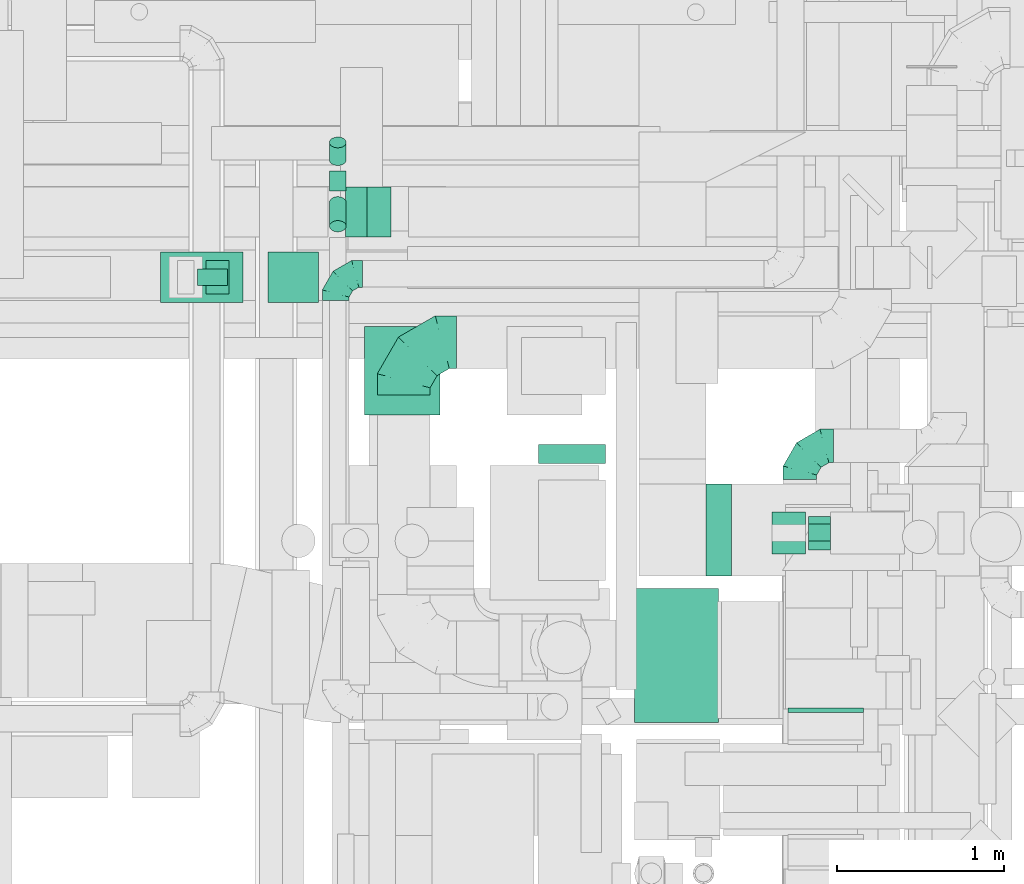
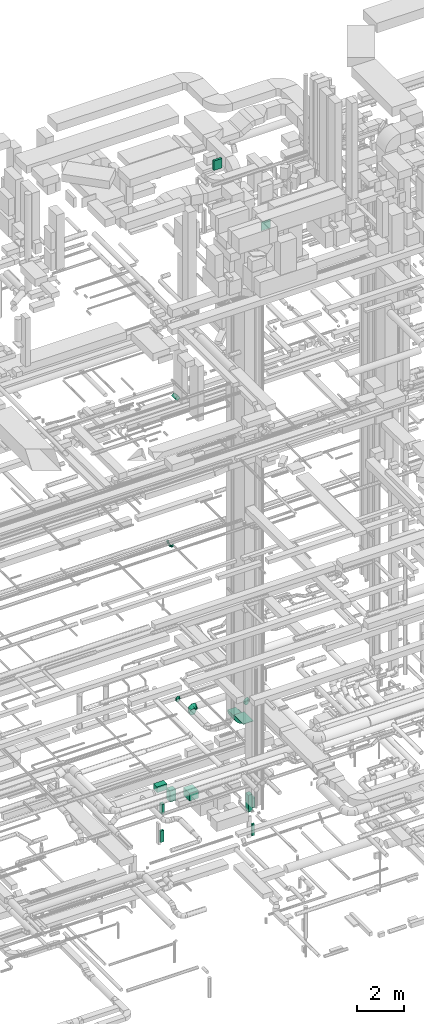
# One storey, part 177 of 337: 13 flow segments, 6 flow fittings.
"""IFC2X3 building model written with IfcOpenShell, lengths in millimetres."""

from ifc_helpers import new_model, entity, si_unit, converted_unit, derived_unit, direction, frame, frame_2d, origin, origin_2d_with_axis, place, context, subcontext, project, spatial, polyline, circle_curve, parameter, trimmed, segment, composite_curve, rectangle, circle, outline, extrude, faceted_brep, source, transform, mapped, material, type_object, type_shapes, element, save


model = new_model("IFC2X3")

# Units and contexts
model_context = context("Model", 3, precision=0.01, world=origin(), true_north=direction((6.12303176911189e-17, 1.0)))
body_context = subcontext(model_context, "Body", "Model", "MODEL_VIEW")
ifc_project = project(units=[si_unit("LENGTHUNIT", "METRE", prefix="MILLI"), si_unit("AREAUNIT", "SQUARE_METRE"), si_unit("VOLUMEUNIT", "CUBIC_METRE"), converted_unit("PLANEANGLEUNIT", "DEGREE", entity("IfcRatioMeasure", 0.0174532925199433), si_unit("PLANEANGLEUNIT", "RADIAN"), dimensions=[0, 0, 0, 0, 0, 0, 0]), si_unit("MASSUNIT", "GRAM", prefix="KILO"), derived_unit("MASSDENSITYUNIT", [(si_unit("MASSUNIT", "GRAM", prefix="KILO"), 1), (si_unit("LENGTHUNIT", "METRE"), -3)]), derived_unit("MOMENTOFINERTIAUNIT", [(si_unit("LENGTHUNIT", "METRE"), 4)]), si_unit("TIMEUNIT", "SECOND"), si_unit("FREQUENCYUNIT", "HERTZ"), si_unit("THERMODYNAMICTEMPERATUREUNIT", "DEGREE_CELSIUS"), derived_unit("THERMALTRANSMITTANCEUNIT", [(si_unit("MASSUNIT", "GRAM", prefix="KILO"), 1), (si_unit("THERMODYNAMICTEMPERATUREUNIT", "KELVIN"), -1), (si_unit("TIMEUNIT", "SECOND"), -3)]), derived_unit("VOLUMETRICFLOWRATEUNIT", [(si_unit("LENGTHUNIT", "METRE"), 3), (si_unit("TIMEUNIT", "SECOND"), -1)]), derived_unit("MASSFLOWRATEUNIT", [(si_unit("MASSUNIT", "GRAM", prefix="KILO"), 1), (si_unit("TIMEUNIT", "SECOND"), -1)]), derived_unit("ROTATIONALFREQUENCYUNIT", [(si_unit("TIMEUNIT", "SECOND"), -1)]), si_unit("ELECTRICCURRENTUNIT", "AMPERE"), si_unit("ELECTRICVOLTAGEUNIT", "VOLT"), si_unit("POWERUNIT", "WATT"), si_unit("FORCEUNIT", "NEWTON", prefix="KILO"), si_unit("ILLUMINANCEUNIT", "LUX"), si_unit("LUMINOUSFLUXUNIT", "LUMEN"), si_unit("LUMINOUSINTENSITYUNIT", "CANDELA"), derived_unit("USERDEFINED", [(si_unit("MASSUNIT", "GRAM", prefix="KILO"), -1), (si_unit("LENGTHUNIT", "METRE"), -2), (si_unit("TIMEUNIT", "SECOND"), 3), (si_unit("LUMINOUSFLUXUNIT", "LUMEN"), 1)]), derived_unit("LINEARVELOCITYUNIT", [(si_unit("LENGTHUNIT", "METRE"), 1), (si_unit("TIMEUNIT", "SECOND"), -1)]), si_unit("PRESSUREUNIT", "PASCAL"), derived_unit("USERDEFINED", [(si_unit("LENGTHUNIT", "METRE"), -2), (si_unit("MASSUNIT", "GRAM", prefix="KILO"), 1), (si_unit("TIMEUNIT", "SECOND"), -2)]), derived_unit("LINEARFORCEUNIT", [(si_unit("MASSUNIT", "GRAM", prefix="KILO"), 1), (si_unit("LENGTHUNIT", "METRE"), 1), (si_unit("TIMEUNIT", "SECOND"), -2), (si_unit("LENGTHUNIT", "METRE"), -1)]), derived_unit("PLANARFORCEUNIT", [(si_unit("MASSUNIT", "GRAM", prefix="KILO"), 1), (si_unit("LENGTHUNIT", "METRE"), 1), (si_unit("TIMEUNIT", "SECOND"), -2), (si_unit("LENGTHUNIT", "METRE"), -2)])], contexts=[model_context])

# Site, building, storey
site_placement = place(None, origin())
site = spatial("IfcSite", under=ifc_project, at=site_placement, CompositionType="ELEMENT")
building_placement = place(site_placement, origin())
building = spatial("IfcBuilding", under=site, at=building_placement, CompositionType="ELEMENT")
storey_placement = place(building_placement, origin())
storey = spatial("IfcBuildingStorey", under=building, at=storey_placement, CompositionType="ELEMENT", Elevation=0.0)

# Flow segments
duct_segment_type_1 = type_object("IfcDuctSegmentType", PredefinedType="NOTDEFINED")
flow_segment_1_placement = place(storey_placement, frame((43382.27, 13725.33, -1300.0)))
element("IfcFlowSegment", 1, at=flow_segment_1_placement, inside=storey, type_object=duct_segment_type_1, context=body_context, shape_type="SweptSolid", body=[
    extrude(rectangle(XDim=528.061629999965, YDim=450.000000000002, at=origin_2d_with_axis()), frame((225.0, 264.03, 0.0), z_axis=(0.0, 0.0, 1.0), x_axis=(0.0, 1.0, 0.0)), (0.0, 0.0, 1.0), 400.0),
])
flow_segment_2_placement = place(storey_placement, frame((45814.19, 12895.83, -2240.0)))
element("IfcFlowSegment", 2, at=flow_segment_2_placement, inside=storey, type_object=duct_segment_type_1, context=body_context, shape_type="SweptSolid", body=[
    extrude(rectangle(XDim=249.999999999999, YDim=199.999999999998, at=origin_2d_with_axis()), frame((100.0, 125.0, 0.0), z_axis=(0.0, 0.0, 1.0), x_axis=(0.0, 1.0, 0.0)), (0.0, 0.0, 1.0), 890.000000000072),
])
flow_segment_3_placement = place(storey_placement, frame((46034.19, 12920.83, -2100.0)))
element("IfcFlowSegment", 3, at=flow_segment_3_placement, inside=storey, type_object=duct_segment_type_1, context=body_context, shape_type="SweptSolid", body=[
    extrude(rectangle(XDim=129.999974999999, YDim=200.0, at=origin_2d_with_axis()), frame((65.0, 100.0, 0.0)), (0.0, 0.0, 1.0), 500.0),
])
flow_segment_4_placement = place(storey_placement, frame((46034.19, 12974.36, -3600.0)))
element("IfcFlowSegment", 4, at=flow_segment_4_placement, inside=storey, type_object=duct_segment_type_1, context=body_context, shape_type="SweptSolid", body=[
    extrude(rectangle(XDim=129.999974999982, YDim=99.9999999999989, at=origin_2d_with_axis()), frame((65.0, 50.0, 0.0)), (0.0, 0.0, 1.0), 600.0),
])
flow_segment_5_placement = place(storey_placement, frame((42807.3, 14398.39, -1565.0)))
element("IfcFlowSegment", 5, at=flow_segment_5_placement, inside=storey, type_object=duct_segment_type_1, context=body_context, shape_type="SweptSolid", body=[
    extrude(rectangle(XDim=300.000000000001, YDim=299.999999999999, at=origin_2d_with_axis()), frame((150.0, 150.0, 0.0), z_axis=(0.0, 0.0, 1.0), x_axis=(-1.0, 0.0, 0.0)), (0.0, 0.0, 1.0), 564.999999999969),
])
flow_segment_6_placement = place(storey_placement, frame((42164.53, 14398.39, -850.0)))
element("IfcFlowSegment", 6, at=flow_segment_6_placement, inside=storey, type_object=duct_segment_type_1, context=body_context, shape_type="SweptSolid", body=[
    extrude(rectangle(XDim=492.776150000064, YDim=299.999999999999, at=origin_2d_with_axis()), frame((246.39, 150.0, 0.0), z_axis=(0.0, 0.0, 1.0), x_axis=(-1.0, 0.0, 0.0)), (0.0, 0.0, 1.0), 300.0),
])
flow_segment_7_placement = place(storey_placement, frame((42384.6, 14498.39, -3600.0)))
element("IfcFlowSegment", 7, at=flow_segment_7_placement, inside=storey, type_object=duct_segment_type_1, context=body_context, shape_type="SweptSolid", body=[
    extrude(rectangle(XDim=179.999999999994, YDim=99.9999999999989, at=origin_2d_with_axis()), frame((90.0, 50.0, 0.0)), (0.0, 0.0, 1.0), 600.0),
])
flow_segment_8_placement = place(storey_placement, frame((42434.6, 14448.39, -2100.0)))
element("IfcFlowSegment", 8, at=flow_segment_8_placement, inside=storey, type_object=duct_segment_type_1, context=body_context, shape_type="SweptSolid", body=[
    extrude(rectangle(XDim=139.999999999994, YDim=200.0, at=origin_2d_with_axis()), frame((70.0, 100.0, 0.0)), (0.0, 0.0, 1.0), 500.0),
])
flow_segment_9_placement = place(storey_placement, frame((43269.65, 14788.36, 18952.51)))
element("IfcFlowSegment", 9, at=flow_segment_9_placement, inside=storey, type_object=duct_segment_type_1, context=body_context, shape_type="SweptSolid", body=[
    extrude(rectangle(XDim=181.827201635449, YDim=200.000000000004, at=origin_2d_with_axis()), frame((135.0, 0.0, 135.0), z_axis=(0.0, 1.0, 0.0), x_axis=(-0.707106781186548, 0.0, -0.707106781186548)), (0.0, 0.0, 1.0), 300.000000000003),
])
flow_segment_10_placement = place(storey_placement, frame((44420.31, 13437.27, 31450.0)))
element("IfcFlowSegment", 10, at=flow_segment_10_placement, inside=storey, type_object=duct_segment_type_1, context=body_context, shape_type="SweptSolid", body=[
    extrude(rectangle(XDim=111.85518107329, YDim=400.000000000004, at=origin_2d_with_axis()), frame((200.0, 55.93, 0.0), z_axis=(0.0, 0.0, 1.0), x_axis=(0.0, 1.0, 0.0)), (0.0, 0.0, 1.0), 499.999999999999),
])
duct_segment_type_2 = type_object("IfcDuctSegmentType", PredefinedType="NOTDEFINED")
flow_segment_11_placement = place(storey_placement, frame((43171.14, 15063.22, 11218.4)))
element("IfcFlowSegment", 11, at=flow_segment_11_placement, inside=storey, type_object=duct_segment_type_2, context=body_context, shape_type="SweptSolid", body=[
    extrude(circle(Radius=50.0, at=origin_2d_with_axis()), frame((51.6, 0.0, 51.6), z_axis=(0.0, 1.0, 0.0), x_axis=(-1.0, 0.0, 0.0)), (0.0, 0.0, 1.0), 120.666172473699),
])
flow_segment_12_placement = place(storey_placement, frame((43171.14, 15214.42, 11253.49)))
element("IfcFlowSegment", 12, at=flow_segment_12_placement, inside=storey, type_object=duct_segment_type_2, context=body_context, shape_type="SweptSolid", body=[
    extrude(circle(Radius=50.0, at=origin_2d_with_axis()), frame((51.6, 33.73, 39.9), z_axis=(0.0, 0.766125074379478, 0.64269150485053), x_axis=(1.0, 0.0, 0.0)), (0.0, 0.0, 1.0), 137.716940563644),
])
flow_segment_13_placement = place(storey_placement, frame((43171.14, 14818.33, 11256.91)))
element("IfcFlowSegment", 13, at=flow_segment_13_placement, inside=storey, type_object=duct_segment_type_2, context=body_context, shape_type="SweptSolid", body=[
    extrude(circle(Radius=50.0, at=origin_2d_with_axis()), frame((51.6, 178.0, 38.76), z_axis=(0.0, -0.743294146247178, 0.668964731622437), x_axis=(1.0, 0.0, 0.0)), (0.0, 0.0, 1.0), 192.325279895398),
])

# Flow fittings
ifc_material = material()
duct_fitting_type_1 = type_object("IfcDuctFittingType", PredefinedType="NOTDEFINED", material=ifc_material)
shared_shape_1 = source(origin(), body_context, "Body", "SweptSolid", [
    extrude(rectangle(XDim=24.9999999999999, YDim=500.0, at=origin_2d_with_axis()), frame((12.5, 0.0, -400.0)), (0.0, 0.0, 1.0), 800.0),
])
type_shapes(duct_fitting_type_1, [shared_shape_1])
flow_fitting_1_placement = place(storey_placement, frame((45245.05, 12289.6, 3271.64), z_axis=(0.0, -1.0, 0.0), x_axis=(0.0, 0.0, -1.0)))
element("IfcFlowFitting", 14, at=flow_fitting_1_placement, inside=storey, type_object=duct_fitting_type_1, material=ifc_material, context=body_context, shape_type="MappedRepresentation", body=[
    mapped(shared_shape_1, transform((0.0, 0.0, 0.0), scale=1.0)),
])
duct_fitting_type_2 = type_object("IfcDuctFittingType", PredefinedType="NOTDEFINED", material=ifc_material)
shared_shape_2 = source(origin(), body_context, "Body", "SweptSolid", [
    extrude(rectangle(XDim=26.0960000000007, YDim=450.0, at=origin_2d_with_axis()), frame((6.95, 0.0, -225.0)), (0.0, 0.0, 1.0), 450.0),
])
type_shapes(duct_fitting_type_2, [shared_shape_2])
flow_fitting_2_placement = place(storey_placement, frame((46136.4, 11970.6, 28905.0), z_axis=(0.0, 0.0, -1.0), x_axis=(0.0, -1.0, 0.0)))
element("IfcFlowFitting", 15, at=flow_fitting_2_placement, inside=storey, type_object=duct_fitting_type_2, material=ifc_material, context=body_context, shape_type="MappedRepresentation", body=[
    mapped(shared_shape_2, transform((0.0, 0.0, 0.0), scale=1.0)),
])
duct_fitting_type_3 = type_object("IfcDuctFittingType", PredefinedType="NOTDEFINED", material=ifc_material)
shared_shape_3 = source(origin(), body_context, "Body", "Brep", [
    faceted_brep([(-160.0, 0.0, -80.0), (-160.0, -20.71, -77.27), (-160.0, -40.0, -69.28), (-160.0, -56.57, -56.57), (-160.0, -69.28, -40.0), (-160.0, -77.27, -20.71), (-160.0, -80.0, 0.0), (-160.0, -77.27, 20.71), (-160.0, -69.28, 40.0), (-160.0, -56.57, 56.57), (-160.0, -40.0, 69.28), (-160.0, -20.71, 77.27), (-160.0, 0.0, 80.0), (-160.0, 20.71, 77.27), (-160.0, 40.0, 69.28), (-160.0, 56.57, 56.57), (-160.0, 69.28, 40.0), (-160.0, 77.27, 20.71), (-160.0, 80.0, 0.0), (-160.0, 77.27, -20.71), (-160.0, 69.28, -40.0), (-160.0, 56.57, -56.57), (-160.0, 40.0, -69.28), (-160.0, 20.71, -77.27), (-122.68, 20.71, 77.27), (-127.85, 40.0, 69.28), (-117.13, 0.0, 80.0), (-132.29, 56.57, 56.57), (-137.83, 77.27, 20.71), (-138.56, 80.0, 0.0), (-135.69, 69.28, 40.0), (-135.69, 69.28, -40.0), (-132.29, 56.57, -56.57), (-137.83, 77.27, -20.71), (-122.68, 20.71, -77.27), (-117.13, 0.0, -80.0), (-127.85, 40.0, -69.28), (-111.58, -20.71, -77.27), (-106.41, -40.0, -69.28), (-101.97, -56.57, -56.57), (-98.56, -69.28, -40.0), (-96.42, -77.27, -20.71), (-95.69, -80.0, 0.0), (-96.42, -77.27, 20.71), (-98.56, -69.28, 40.0), (-101.97, -56.57, 56.57), (-106.41, -40.0, 69.28), (-111.58, -20.71, 77.27), (-58.03, 58.03, 77.27), (-72.15, 72.15, 69.28), (-42.87, 42.87, 80.0), (-84.28, 84.28, 56.57), (-93.59, 93.59, 40.0), (-99.44, 99.44, 20.71), (-101.44, 101.44, 0.0), (-99.44, 99.44, -20.71), (-93.59, 93.59, -40.0), (-84.28, 84.28, -56.57), (-58.03, 58.03, -77.27), (-42.87, 42.87, -80.0), (-72.15, 72.15, -69.28), (-27.71, 27.71, -77.27), (-13.59, 13.59, -69.28), (-1.46, 1.46, -56.57), (7.85, -7.85, -40.0), (13.7, -13.7, -20.71), (15.69, -15.69, 0.0), (13.7, -13.7, 20.71), (7.85, -7.85, 40.0), (-1.46, 1.46, 56.57), (-13.59, 13.59, 69.28), (-27.71, 27.71, 77.27), (-20.71, 122.68, 77.27), (-40.0, 127.85, 69.28), (0.0, 117.13, 80.0), (-56.57, 132.29, 56.57), (-69.28, 135.69, 40.0), (-77.27, 137.83, 20.71), (-80.0, 138.56, 0.0), (-77.27, 137.83, -20.71), (-69.28, 135.69, -40.0), (-56.57, 132.29, -56.57), (-20.71, 122.68, -77.27), (0.0, 117.13, -80.0), (-40.0, 127.85, -69.28), (20.71, 111.58, -77.27), (40.0, 106.41, -69.28), (56.57, 101.97, -56.57), (69.28, 98.56, -40.0), (77.27, 96.42, -20.71), (80.0, 95.69, 0.0), (77.27, 96.42, 20.71), (69.28, 98.56, 40.0), (56.57, 101.97, 56.57), (40.0, 106.41, 69.28), (20.71, 111.58, 77.27), (-20.71, 160.0, -77.27), (-40.0, 160.0, -69.28), (-56.57, 160.0, -56.57), (-69.28, 160.0, -40.0), (-77.27, 160.0, -20.71), (-80.0, 160.0, 0.0), (-77.27, 160.0, 20.71), (-69.28, 160.0, 40.0), (-56.57, 160.0, 56.57), (-40.0, 160.0, 69.28), (-20.71, 160.0, 77.27), (0.0, 160.0, 80.0), (20.71, 160.0, 77.27), (40.0, 160.0, 69.28), (56.57, 160.0, 56.57), (69.28, 160.0, 40.0), (77.27, 160.0, 20.71), (80.0, 160.0, 0.0), (77.27, 160.0, -20.71), (69.28, 160.0, -40.0), (56.57, 160.0, -56.57), (40.0, 160.0, -69.28), (20.71, 160.0, -77.27), (0.0, 160.0, -80.0)], [[[0, 1, 2, 3, 4, 5, 6, 7, 8, 9, 10, 11, 12, 13, 14, 15, 16, 17, 18, 19, 20, 21, 22, 23]], [[24, 25, 14, 13]], [[26, 24, 13, 12]], [[14, 25, 27, 15]], [[28, 29, 18, 17]], [[30, 28, 17, 16]], [[15, 27, 30, 16]], [[20, 31, 32, 21]], [[33, 31, 20, 19]], [[18, 29, 33, 19]], [[34, 35, 0, 23]], [[36, 34, 23, 22]], [[32, 36, 22, 21]], [[1, 0, 35, 37]], [[2, 1, 37, 38]], [[3, 2, 38, 39]], [[5, 4, 40, 41]], [[6, 5, 41, 42]], [[39, 40, 4, 3]], [[6, 42, 43, 7]], [[7, 43, 44, 8]], [[8, 44, 45, 9]], [[9, 45, 46, 10]], [[10, 46, 47, 11]], [[26, 12, 11, 47]], [[48, 49, 25, 24]], [[50, 48, 24, 26]], [[27, 25, 49, 51]], [[52, 53, 28, 30]], [[51, 52, 30, 27]], [[29, 28, 53, 54]], [[55, 56, 31, 33]], [[54, 55, 33, 29]], [[32, 31, 56, 57]], [[58, 59, 35, 34]], [[60, 58, 34, 36]], [[57, 60, 36, 32]], [[37, 35, 59, 61]], [[38, 37, 61, 62]], [[39, 38, 62, 63]], [[41, 40, 64, 65]], [[42, 41, 65, 66]], [[63, 64, 40, 39]], [[43, 42, 66, 67]], [[44, 43, 67, 68]], [[68, 69, 45, 44]], [[46, 45, 69, 70]], [[47, 46, 70, 71]], [[26, 47, 71, 50]], [[72, 73, 49, 48]], [[74, 72, 48, 50]], [[51, 49, 73, 75]], [[76, 77, 53, 52]], [[75, 76, 52, 51]], [[54, 53, 77, 78]], [[79, 80, 56, 55]], [[78, 79, 55, 54]], [[57, 56, 80, 81]], [[82, 83, 59, 58]], [[84, 82, 58, 60]], [[81, 84, 60, 57]], [[61, 59, 83, 85]], [[62, 61, 85, 86]], [[63, 62, 86, 87]], [[65, 64, 88, 89]], [[66, 65, 89, 90]], [[87, 88, 64, 63]], [[67, 66, 90, 91]], [[68, 67, 91, 92]], [[92, 93, 69, 68]], [[70, 69, 93, 94]], [[71, 70, 94, 95]], [[50, 71, 95, 74]], [[96, 97, 98, 99, 100, 101, 102, 103, 104, 105, 106, 107, 108, 109, 110, 111, 112, 113, 114, 115, 116, 117, 118, 119]], [[72, 74, 107, 106]], [[73, 72, 106, 105]], [[75, 73, 105, 104]], [[77, 76, 103, 102]], [[78, 77, 102, 101]], [[75, 104, 103, 76]], [[78, 101, 100, 79]], [[79, 100, 99, 80]], [[80, 99, 98, 81]], [[84, 97, 96, 82]], [[82, 96, 119, 83]], [[84, 81, 98, 97]], [[118, 117, 86, 85]], [[119, 118, 85, 83]], [[116, 87, 86, 117]], [[88, 115, 114, 89]], [[89, 114, 113, 90]], [[115, 88, 87, 116]], [[112, 111, 92, 91]], [[113, 112, 91, 90]], [[111, 110, 93, 92]], [[95, 94, 109, 108]], [[74, 95, 108, 107]], [[110, 109, 94, 93]]]),
])
type_shapes(duct_fitting_type_3, [shared_shape_3])
flow_fitting_3_placement = place(storey_placement, frame((43210.25, 14568.87, 3600.0), z_axis=(0.0, 0.0, 1.0), x_axis=(-1.0, 0.0, 0.0)))
element("IfcFlowFitting", 16, at=flow_fitting_3_placement, inside=storey, type_object=duct_fitting_type_3, material=ifc_material, context=body_context, shape_type="MappedRepresentation", body=[
    mapped(shared_shape_3, transform((0.0, 0.0, 0.0), scale=1.0)),
])
duct_fitting_type_4 = type_object("IfcDuctFittingType", PredefinedType="NOTDEFINED", material=ifc_material)
shared_shape_4 = source(origin(), body_context, "Body", "Brep", [
    faceted_brep([(-200.0, 0.0, -100.0), (-200.0, -25.88, -96.59), (-200.0, -50.0, -86.6), (-200.0, -70.71, -70.71), (-200.0, -86.6, -50.0), (-200.0, -96.59, -25.88), (-200.0, -100.0, 0.0), (-200.0, -96.59, 25.88), (-200.0, -86.6, 50.0), (-200.0, -70.71, 70.71), (-200.0, -50.0, 86.6), (-200.0, -25.88, 96.59), (-200.0, 0.0, 100.0), (-200.0, 25.88, 96.59), (-200.0, 50.0, 86.6), (-200.0, 70.71, 70.71), (-200.0, 86.6, 50.0), (-200.0, 96.59, 25.88), (-200.0, 100.0, 0.0), (-200.0, 96.59, -25.88), (-200.0, 86.6, -50.0), (-200.0, 70.71, -70.71), (-200.0, 50.0, -86.6), (-200.0, 25.88, -96.59), (-153.35, 25.88, 96.59), (-159.81, 50.0, 86.6), (-146.41, 0.0, 100.0), (-165.36, 70.71, 70.71), (-172.29, 96.59, 25.88), (-173.21, 100.0, 0.0), (-169.62, 86.6, 50.0), (-169.62, 86.6, -50.0), (-165.36, 70.71, -70.71), (-172.29, 96.59, -25.88), (-153.35, 25.88, -96.59), (-146.41, 0.0, -100.0), (-159.81, 50.0, -86.6), (-139.48, -25.88, -96.59), (-133.01, -50.0, -86.6), (-127.46, -70.71, -70.71), (-123.21, -86.6, -50.0), (-120.53, -96.59, -25.88), (-119.62, -100.0, 0.0), (-120.53, -96.59, 25.88), (-123.21, -86.6, 50.0), (-127.46, -70.71, 70.71), (-133.01, -50.0, 86.6), (-139.48, -25.88, 96.59), (-72.54, 72.54, 96.59), (-90.19, 90.19, 86.6), (-53.59, 53.59, 100.0), (-105.35, 105.35, 70.71), (-116.99, 116.99, 50.0), (-124.3, 124.3, 25.88), (-126.79, 126.79, 0.0), (-124.3, 124.3, -25.88), (-116.99, 116.99, -50.0), (-105.35, 105.35, -70.71), (-72.54, 72.54, -96.59), (-53.59, 53.59, -100.0), (-90.19, 90.19, -86.6), (-34.64, 34.64, -96.59), (-16.99, 16.99, -86.6), (-1.83, 1.83, -70.71), (9.81, -9.81, -50.0), (17.12, -17.12, -25.88), (19.62, -19.62, 0.0), (17.12, -17.12, 25.88), (9.81, -9.81, 50.0), (-1.83, 1.83, 70.71), (-16.99, 16.99, 86.6), (-34.64, 34.64, 96.59), (-25.88, 153.35, 96.59), (-50.0, 159.81, 86.6), (0.0, 146.41, 100.0), (-70.71, 165.36, 70.71), (-86.6, 169.62, 50.0), (-96.59, 172.29, 25.88), (-100.0, 173.21, 0.0), (-96.59, 172.29, -25.88), (-86.6, 169.62, -50.0), (-70.71, 165.36, -70.71), (-25.88, 153.35, -96.59), (0.0, 146.41, -100.0), (-50.0, 159.81, -86.6), (25.88, 139.48, -96.59), (50.0, 133.01, -86.6), (70.71, 127.46, -70.71), (86.6, 123.21, -50.0), (96.59, 120.53, -25.88), (100.0, 119.62, 0.0), (96.59, 120.53, 25.88), (86.6, 123.21, 50.0), (70.71, 127.46, 70.71), (50.0, 133.01, 86.6), (25.88, 139.48, 96.59), (-25.88, 200.0, -96.59), (-50.0, 200.0, -86.6), (-70.71, 200.0, -70.71), (-86.6, 200.0, -50.0), (-96.59, 200.0, -25.88), (-100.0, 200.0, 0.0), (-96.59, 200.0, 25.88), (-86.6, 200.0, 50.0), (-70.71, 200.0, 70.71), (-50.0, 200.0, 86.6), (-25.88, 200.0, 96.59), (0.0, 200.0, 100.0), (25.88, 200.0, 96.59), (50.0, 200.0, 86.6), (70.71, 200.0, 70.71), (86.6, 200.0, 50.0), (96.59, 200.0, 25.88), (100.0, 200.0, 0.0), (96.59, 200.0, -25.88), (86.6, 200.0, -50.0), (70.71, 200.0, -70.71), (50.0, 200.0, -86.6), (25.88, 200.0, -96.59), (0.0, 200.0, -100.0)], [[[0, 1, 2, 3, 4, 5, 6, 7, 8, 9, 10, 11, 12, 13, 14, 15, 16, 17, 18, 19, 20, 21, 22, 23]], [[24, 25, 14, 13]], [[26, 24, 13, 12]], [[14, 25, 27, 15]], [[28, 29, 18, 17]], [[30, 28, 17, 16]], [[15, 27, 30, 16]], [[20, 31, 32, 21]], [[33, 31, 20, 19]], [[18, 29, 33, 19]], [[34, 35, 0, 23]], [[36, 34, 23, 22]], [[32, 36, 22, 21]], [[1, 0, 35, 37]], [[2, 1, 37, 38]], [[38, 39, 3, 2]], [[5, 4, 40, 41]], [[6, 5, 41, 42]], [[39, 40, 4, 3]], [[6, 42, 43, 7]], [[7, 43, 44, 8]], [[8, 44, 45, 9]], [[9, 45, 46, 10]], [[10, 46, 47, 11]], [[26, 12, 11, 47]], [[48, 49, 25, 24]], [[50, 48, 24, 26]], [[27, 25, 49, 51]], [[52, 53, 28, 30]], [[51, 52, 30, 27]], [[29, 28, 53, 54]], [[55, 56, 31, 33]], [[54, 55, 33, 29]], [[32, 31, 56, 57]], [[58, 59, 35, 34]], [[60, 58, 34, 36]], [[57, 60, 36, 32]], [[37, 35, 59, 61]], [[38, 37, 61, 62]], [[39, 38, 62, 63]], [[41, 40, 64, 65]], [[42, 41, 65, 66]], [[63, 64, 40, 39]], [[43, 42, 66, 67]], [[44, 43, 67, 68]], [[68, 69, 45, 44]], [[46, 45, 69, 70]], [[47, 46, 70, 71]], [[26, 47, 71, 50]], [[72, 73, 49, 48]], [[74, 72, 48, 50]], [[51, 49, 73, 75]], [[76, 77, 53, 52]], [[75, 76, 52, 51]], [[54, 53, 77, 78]], [[79, 80, 56, 55]], [[78, 79, 55, 54]], [[57, 56, 80, 81]], [[82, 83, 59, 58]], [[84, 82, 58, 60]], [[81, 84, 60, 57]], [[61, 59, 83, 85]], [[62, 61, 85, 86]], [[63, 62, 86, 87]], [[65, 64, 88, 89]], [[66, 65, 89, 90]], [[87, 88, 64, 63]], [[67, 66, 90, 91]], [[68, 67, 91, 92]], [[92, 93, 69, 68]], [[70, 69, 93, 94]], [[71, 70, 94, 95]], [[50, 71, 95, 74]], [[96, 97, 98, 99, 100, 101, 102, 103, 104, 105, 106, 107, 108, 109, 110, 111, 112, 113, 114, 115, 116, 117, 118, 119]], [[72, 74, 107, 106]], [[73, 72, 106, 105]], [[75, 73, 105, 104]], [[102, 101, 78, 77]], [[103, 102, 77, 76]], [[75, 104, 103, 76]], [[78, 101, 100, 79]], [[79, 100, 99, 80]], [[80, 99, 98, 81]], [[84, 97, 96, 82]], [[82, 96, 119, 83]], [[84, 81, 98, 97]], [[118, 117, 86, 85]], [[119, 118, 85, 83]], [[116, 87, 86, 117]], [[88, 115, 114, 89]], [[89, 114, 113, 90]], [[115, 88, 87, 116]], [[91, 90, 113, 112]], [[92, 91, 112, 111]], [[111, 110, 93, 92]], [[95, 94, 109, 108]], [[74, 95, 108, 107]], [[110, 109, 94, 93]]]),
])
type_shapes(duct_fitting_type_4, [shared_shape_4])
flow_fitting_4_placement = place(storey_placement, frame((45982.19, 13541.07, 3150.0), z_axis=(0.0, 0.0, 1.0), x_axis=(-1.0, 0.0, 0.0)))
element("IfcFlowFitting", 17, at=flow_fitting_4_placement, inside=storey, type_object=duct_fitting_type_4, material=ifc_material, context=body_context, shape_type="MappedRepresentation", body=[
    mapped(shared_shape_4, transform((0.0, 0.0, 0.0), scale=1.0)),
])
duct_fitting_type_5 = type_object("IfcDuctFittingType", PredefinedType="NOTDEFINED", material=ifc_material)
shared_shape_5 = source(origin(), body_context, "Body", "Brep", [
    faceted_brep([(-315.0, 0.0, -157.5), (-315.0, -40.76, -152.13), (-315.0, -78.75, -136.4), (-315.0, -111.37, -111.37), (-315.0, -136.4, -78.75), (-315.0, -152.13, -40.76), (-315.0, -157.5, 0.0), (-315.0, -152.13, 40.76), (-315.0, -136.4, 78.75), (-315.0, -111.37, 111.37), (-315.0, -78.75, 136.4), (-315.0, -40.76, 152.13), (-315.0, 0.0, 157.5), (-315.0, 40.76, 152.13), (-315.0, 78.75, 136.4), (-315.0, 111.37, 111.37), (-315.0, 136.4, 78.75), (-315.0, 152.13, 40.76), (-315.0, 157.5, 0.0), (-315.0, 152.13, -40.76), (-315.0, 136.4, -78.75), (-315.0, 111.37, -111.37), (-315.0, 78.75, -136.4), (-315.0, 40.76, -152.13), (-241.52, 40.76, 152.13), (-251.7, 78.75, 136.4), (-230.6, 0.0, 157.5), (-260.44, 111.37, 111.37), (-271.36, 152.13, 40.76), (-272.8, 157.5, 0.0), (-267.14, 136.4, 78.75), (-267.14, 136.4, -78.75), (-260.44, 111.37, -111.37), (-271.36, 152.13, -40.76), (-241.52, 40.76, -152.13), (-230.6, 0.0, -157.5), (-251.7, 78.75, -136.4), (-219.67, -40.76, -152.13), (-209.5, -78.75, -136.4), (-200.75, -111.37, -111.37), (-194.05, -136.4, -78.75), (-189.83, -152.13, -40.76), (-188.39, -157.5, 0.0), (-189.83, -152.13, 40.76), (-194.05, -136.4, 78.75), (-200.75, -111.37, 111.37), (-209.5, -78.75, 136.4), (-219.67, -40.76, 152.13), (-114.25, 114.25, 152.13), (-142.05, 142.05, 136.4), (-84.4, 84.4, 157.5), (-165.93, 165.93, 111.37), (-184.25, 184.25, 78.75), (-195.77, 195.77, 40.76), (-199.7, 199.7, 0.0), (-195.77, 195.77, -40.76), (-184.25, 184.25, -78.75), (-165.93, 165.93, -111.37), (-114.25, 114.25, -152.13), (-84.4, 84.4, -157.5), (-142.05, 142.05, -136.4), (-54.56, 54.56, -152.13), (-26.75, 26.75, -136.4), (-2.88, 2.88, -111.37), (15.45, -15.45, -78.75), (26.97, -26.97, -40.76), (30.89, -30.89, 0.0), (26.97, -26.97, 40.76), (15.45, -15.45, 78.75), (-2.88, 2.88, 111.37), (-26.75, 26.75, 136.4), (-54.56, 54.56, 152.13), (-40.76, 241.52, 152.13), (-78.75, 251.7, 136.4), (0.0, 230.6, 157.5), (-111.37, 260.44, 111.37), (-136.4, 267.14, 78.75), (-152.13, 271.36, 40.76), (-157.5, 272.8, 0.0), (-152.13, 271.36, -40.76), (-136.4, 267.14, -78.75), (-111.37, 260.44, -111.37), (-40.76, 241.52, -152.13), (0.0, 230.6, -157.5), (-78.75, 251.7, -136.4), (40.76, 219.67, -152.13), (78.75, 209.5, -136.4), (111.37, 200.75, -111.37), (136.4, 194.05, -78.75), (152.13, 189.83, -40.76), (157.5, 188.39, 0.0), (152.13, 189.83, 40.76), (136.4, 194.05, 78.75), (111.37, 200.75, 111.37), (78.75, 209.5, 136.4), (40.76, 219.67, 152.13), (-40.76, 315.0, -152.13), (-78.75, 315.0, -136.4), (-111.37, 315.0, -111.37), (-136.4, 315.0, -78.75), (-152.13, 315.0, -40.76), (-157.5, 315.0, 0.0), (-152.13, 315.0, 40.76), (-136.4, 315.0, 78.75), (-111.37, 315.0, 111.37), (-78.75, 315.0, 136.4), (-40.76, 315.0, 152.13), (0.0, 315.0, 157.5), (40.76, 315.0, 152.13), (78.75, 315.0, 136.4), (111.37, 315.0, 111.37), (136.4, 315.0, 78.75), (152.13, 315.0, 40.76), (157.5, 315.0, 0.0), (152.13, 315.0, -40.76), (136.4, 315.0, -78.75), (111.37, 315.0, -111.37), (78.75, 315.0, -136.4), (40.76, 315.0, -152.13), (0.0, 315.0, -157.5)], [[[0, 1, 2, 3, 4, 5, 6, 7, 8, 9, 10, 11, 12, 13, 14, 15, 16, 17, 18, 19, 20, 21, 22, 23]], [[24, 25, 14, 13]], [[26, 24, 13, 12]], [[14, 25, 27, 15]], [[28, 29, 18, 17]], [[30, 28, 17, 16]], [[15, 27, 30, 16]], [[20, 31, 32, 21]], [[33, 31, 20, 19]], [[18, 29, 33, 19]], [[34, 35, 0, 23]], [[36, 34, 23, 22]], [[32, 36, 22, 21]], [[1, 0, 35, 37]], [[2, 1, 37, 38]], [[38, 39, 3, 2]], [[5, 4, 40, 41]], [[6, 5, 41, 42]], [[39, 40, 4, 3]], [[6, 42, 43, 7]], [[7, 43, 44, 8]], [[8, 44, 45, 9]], [[9, 45, 46, 10]], [[10, 46, 47, 11]], [[26, 12, 11, 47]], [[48, 49, 25, 24]], [[50, 48, 24, 26]], [[27, 25, 49, 51]], [[52, 53, 28, 30]], [[51, 52, 30, 27]], [[29, 28, 53, 54]], [[55, 56, 31, 33]], [[54, 55, 33, 29]], [[32, 31, 56, 57]], [[58, 59, 35, 34]], [[60, 58, 34, 36]], [[57, 60, 36, 32]], [[37, 35, 59, 61]], [[38, 37, 61, 62]], [[39, 38, 62, 63]], [[41, 40, 64, 65]], [[42, 41, 65, 66]], [[63, 64, 40, 39]], [[43, 42, 66, 67]], [[44, 43, 67, 68]], [[68, 69, 45, 44]], [[46, 45, 69, 70]], [[47, 46, 70, 71]], [[26, 47, 71, 50]], [[72, 73, 49, 48]], [[74, 72, 48, 50]], [[51, 49, 73, 75]], [[76, 77, 53, 52]], [[75, 76, 52, 51]], [[54, 53, 77, 78]], [[79, 80, 56, 55]], [[78, 79, 55, 54]], [[57, 56, 80, 81]], [[82, 83, 59, 58]], [[84, 82, 58, 60]], [[81, 84, 60, 57]], [[61, 59, 83, 85]], [[62, 61, 85, 86]], [[63, 62, 86, 87]], [[65, 64, 88, 89]], [[66, 65, 89, 90]], [[87, 88, 64, 63]], [[67, 66, 90, 91]], [[68, 67, 91, 92]], [[92, 93, 69, 68]], [[70, 69, 93, 94]], [[71, 70, 94, 95]], [[50, 71, 95, 74]], [[96, 97, 98, 99, 100, 101, 102, 103, 104, 105, 106, 107, 108, 109, 110, 111, 112, 113, 114, 115, 116, 117, 118, 119]], [[106, 105, 73, 72]], [[107, 106, 72, 74]], [[75, 73, 105, 104]], [[77, 76, 103, 102]], [[78, 77, 102, 101]], [[104, 103, 76, 75]], [[78, 101, 100, 79]], [[79, 100, 99, 80]], [[98, 81, 80, 99]], [[84, 97, 96, 82]], [[82, 96, 119, 83]], [[97, 84, 81, 98]], [[83, 119, 118, 85]], [[85, 118, 117, 86]], [[116, 87, 86, 117]], [[88, 115, 114, 89]], [[89, 114, 113, 90]], [[115, 88, 87, 116]], [[91, 90, 113, 112]], [[92, 91, 112, 111]], [[111, 110, 93, 92]], [[95, 94, 109, 108]], [[74, 95, 108, 107]], [[110, 109, 94, 93]]]),
])
type_shapes(duct_fitting_type_5, [shared_shape_5])
flow_fitting_5_placement = place(storey_placement, frame((43616.18, 14160.95, 3200.0), z_axis=(0.0, 0.0, 1.0), x_axis=(-1.0, 0.0, 0.0)))
element("IfcFlowFitting", 18, at=flow_fitting_5_placement, inside=storey, type_object=duct_fitting_type_5, material=ifc_material, context=body_context, shape_type="MappedRepresentation", body=[
    mapped(shared_shape_5, transform((0.0, 0.0, 0.0), scale=1.0)),
])
duct_fitting_type_6 = type_object("IfcDuctFittingType", PredefinedType="NOTDEFINED", material=ifc_material)
shared_shape_6 = source(origin(), body_context, "Body", "SweptSolid", [
    extrude(outline(composite_curve([segment(polyline([(-375.0, -175.0), (25.0, -175.0)]), True, "CONTINUOUS"), segment(trimmed(circle_curve(frame_2d((175.0, -175.0), x_axis=(0.0, 1.0)), 150.0), [parameter(0.0)], [parameter(90.0000000000001)], True, "PARAMETER"), False, "CONTINUOUS"), segment(polyline([(175.0, -25.0), (175.0, 375.0)]), True, "CONTINUOUS"), segment(trimmed(circle_curve(frame_2d((175.0, -175.0), x_axis=(0.0, 1.0)), 550.0), [parameter(0.0)], [parameter(90.0)], True, "PARAMETER"), True, "CONTINUOUS")], self_intersect=False)), frame((-175.0, 175.0, -275.0), z_axis=(0.0, 0.0, 1.0), x_axis=(-1.0, 0.0, 0.0)), (0.0, 0.0, 1.0), 550.0),
])
type_shapes(duct_fitting_type_6, [shared_shape_6])
flow_fitting_6_placement = place(storey_placement, frame((45222.31, 13039.41, 2800.0), z_axis=(0.0, -1.0, 0.0), x_axis=(0.0, 0.0, -1.0)))
element("IfcFlowFitting", 19, at=flow_fitting_6_placement, inside=storey, type_object=duct_fitting_type_6, material=ifc_material, context=body_context, shape_type="MappedRepresentation", body=[
    mapped(shared_shape_6, transform((0.0, 0.0, 0.0), scale=1.0)),
])

save(model, "model.ifc")
